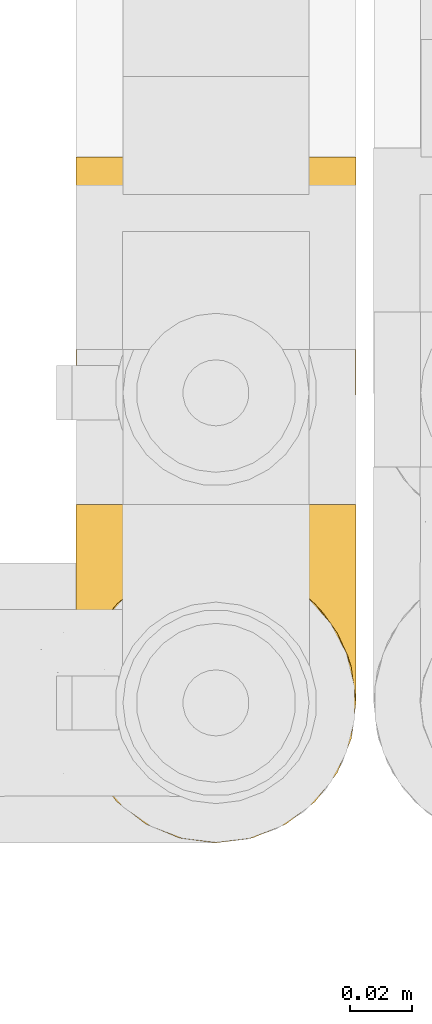
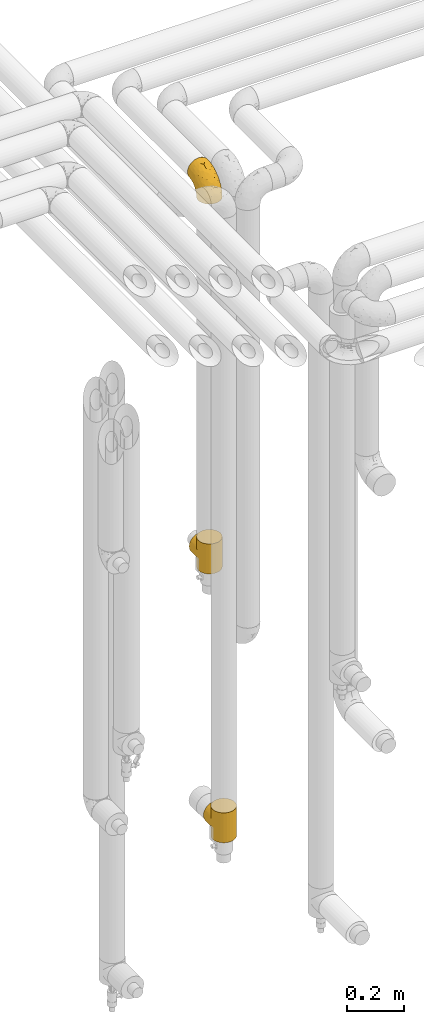
# One storey, part 258 of 827: 3 coverings.
"""IFC2X3 building model written with IfcOpenShell, lengths in millimetres."""

from ifc_helpers import new_model, entity, si_unit, converted_unit, derived_unit, direction, frame, origin, place, context, subcontext, project, spatial, faceted_brep, element, save


model = new_model("IFC2X3")

# Units and contexts
model_context = context("Model", 3, precision=0.01, world=origin(), true_north=direction((6.12303176911189e-17, 1.0)))
body_context = subcontext(model_context, "Body", "Model", "MODEL_VIEW")
ifc_project = project(units=[si_unit("LENGTHUNIT", "METRE", prefix="MILLI"), si_unit("AREAUNIT", "SQUARE_METRE"), si_unit("VOLUMEUNIT", "CUBIC_METRE"), converted_unit("PLANEANGLEUNIT", "DEGREE", entity("IfcRatioMeasure", 0.0174532925199433), si_unit("PLANEANGLEUNIT", "RADIAN"), dimensions=[0, 0, 0, 0, 0, 0, 0]), si_unit("MASSUNIT", "GRAM", prefix="KILO"), derived_unit("MASSDENSITYUNIT", [(si_unit("MASSUNIT", "GRAM", prefix="KILO"), 1), (si_unit("LENGTHUNIT", "METRE"), -3)]), derived_unit("MOMENTOFINERTIAUNIT", [(si_unit("LENGTHUNIT", "METRE"), 4)]), si_unit("TIMEUNIT", "SECOND"), si_unit("FREQUENCYUNIT", "HERTZ"), si_unit("THERMODYNAMICTEMPERATUREUNIT", "DEGREE_CELSIUS"), derived_unit("THERMALTRANSMITTANCEUNIT", [(si_unit("MASSUNIT", "GRAM", prefix="KILO"), 1), (si_unit("THERMODYNAMICTEMPERATUREUNIT", "KELVIN"), -1), (si_unit("TIMEUNIT", "SECOND"), -3)]), derived_unit("VOLUMETRICFLOWRATEUNIT", [(si_unit("LENGTHUNIT", "METRE"), 3), (si_unit("TIMEUNIT", "SECOND"), -1)]), derived_unit("MASSFLOWRATEUNIT", [(si_unit("MASSUNIT", "GRAM", prefix="KILO"), 1), (si_unit("TIMEUNIT", "SECOND"), -1)]), derived_unit("ROTATIONALFREQUENCYUNIT", [(si_unit("TIMEUNIT", "SECOND"), -1)]), si_unit("ELECTRICCURRENTUNIT", "AMPERE"), si_unit("ELECTRICVOLTAGEUNIT", "VOLT"), si_unit("POWERUNIT", "WATT"), si_unit("FORCEUNIT", "NEWTON", prefix="KILO"), si_unit("ILLUMINANCEUNIT", "LUX"), si_unit("LUMINOUSFLUXUNIT", "LUMEN"), si_unit("LUMINOUSINTENSITYUNIT", "CANDELA"), derived_unit("USERDEFINED", [(si_unit("MASSUNIT", "GRAM", prefix="KILO"), -1), (si_unit("LENGTHUNIT", "METRE"), -2), (si_unit("TIMEUNIT", "SECOND"), 3), (si_unit("LUMINOUSFLUXUNIT", "LUMEN"), 1)]), derived_unit("LINEARVELOCITYUNIT", [(si_unit("LENGTHUNIT", "METRE"), 1), (si_unit("TIMEUNIT", "SECOND"), -1)]), si_unit("PRESSUREUNIT", "PASCAL"), derived_unit("USERDEFINED", [(si_unit("LENGTHUNIT", "METRE"), -2), (si_unit("MASSUNIT", "GRAM", prefix="KILO"), 1), (si_unit("TIMEUNIT", "SECOND"), -2)]), derived_unit("LINEARFORCEUNIT", [(si_unit("MASSUNIT", "GRAM", prefix="KILO"), 1), (si_unit("LENGTHUNIT", "METRE"), 1), (si_unit("TIMEUNIT", "SECOND"), -2), (si_unit("LENGTHUNIT", "METRE"), -1)]), derived_unit("PLANARFORCEUNIT", [(si_unit("MASSUNIT", "GRAM", prefix="KILO"), 1), (si_unit("LENGTHUNIT", "METRE"), 1), (si_unit("TIMEUNIT", "SECOND"), -2), (si_unit("LENGTHUNIT", "METRE"), -2)])], contexts=[model_context])

# Site, building, storey
site_placement = place(None, origin())
site = spatial("IfcSite", under=ifc_project, at=site_placement, CompositionType="ELEMENT")
building_placement = place(site_placement, origin())
building = spatial("IfcBuilding", under=site, at=building_placement, CompositionType="ELEMENT")
storey_placement = place(building_placement, frame((0.0, 0.0, 28200.0)))
storey = spatial("IfcBuildingStorey", under=building, at=storey_placement, Name="08", CompositionType="ELEMENT", Elevation=28200.0)

# Coverings
covering_1_placement = place(storey_placement, frame((31537.51, 15764.46, 2922.4)))
element("IfcCovering", 1, at=covering_1_placement, inside=storey, Name=":ADSK_", ObjectType=":ADSK_", PredefinedType="INSULATION", context=body_context, shape_type="Brep", body=[
    faceted_brep([(90.76, 36.69, 1.6), (87.42, 27.15, 1.6), (82.04, 18.59, 1.6), (74.89, 11.44, 1.6), (66.33, 6.06, 1.6), (56.79, 2.73, 1.6), (46.75, 1.6, 1.6), (36.69, 2.73, 1.6), (27.15, 6.07, 1.6), (18.59, 11.45, 1.6), (11.44, 18.6, 1.6), (6.06, 27.16, 1.6), (2.73, 36.7, 1.6), (1.6, 46.75, 1.6), (2.73, 56.8, 1.6), (6.07, 66.34, 1.6), (11.45, 74.9, 1.6), (18.6, 82.05, 1.6), (27.16, 87.43, 1.6), (36.7, 90.76, 1.6), (46.75, 91.9, 1.6), (56.8, 90.76, 1.6), (66.34, 87.42, 1.6), (74.9, 82.04, 1.6), (82.05, 74.89, 1.6), (87.43, 66.33, 1.6), (90.76, 56.79, 1.6), (91.9, 46.75, 1.6), (35.06, 122.75, 33.98), (24.17, 122.75, 38.49), (14.82, 122.75, 45.67), (7.64, 122.75, 55.02), (3.13, 122.75, 65.91), (1.6, 122.75, 77.6), (3.13, 122.75, 89.28), (7.64, 122.75, 100.17), (14.82, 122.75, 109.52), (24.17, 122.75, 116.7), (35.06, 122.75, 121.21), (46.75, 122.75, 122.75), (58.43, 122.75, 121.21), (69.32, 122.75, 116.7), (78.67, 122.75, 109.52), (85.85, 122.75, 100.17), (90.36, 122.75, 89.28), (91.9, 122.75, 77.6), (90.36, 122.75, 65.91), (85.85, 122.75, 55.02), (78.67, 122.75, 45.67), (69.32, 122.75, 38.49), (58.43, 122.75, 33.98), (46.75, 122.75, 32.45), (46.75, 24.73, 72.81), (55.2, 29.08, 77.17), (46.75, 38.13, 86.21), (46.75, 85.31, 116.82), (54.53, 93.59, 118.49), (46.75, 100.54, 119.23), (59.63, 63.54, 105.14), (62.07, 38.98, 85.37), (71.86, 50.71, 89.33), (62.65, 93.33, 116.14), (71.33, 75.2, 105.06), (72.93, 100.46, 112.15), (91.2, 41.6, 22.95), (86.31, 80.86, 89.91), (80.89, 94.87, 103.39), (79.49, 67.96, 93.6), (90.68, 52.16, 51.41), (86.84, 52.1, 67.71), (87.38, 36.74, 43.53), (76.87, 17.11, 30.91), (83.73, 23.24, 23.58), (81.03, 29.18, 50.07), (91.9, 52.53, 30.68), (91.9, 60.77, 43.01), (91.9, 69.01, 55.34), (91.03, 100.68, 83.48), (87.58, 103.79, 94.96), (56.52, 16.37, 57.29), (46.75, 7.52, 39.03), (60.4, 7.31, 30.66), (91.9, 93.66, 71.81), (91.9, 102.83, 73.63), (91.9, 112.01, 75.46), (67.87, 18.17, 51.57), (90.35, 71.97, 73.13), (69.57, 9.83, 23.16), (46.75, 5.11, 23.8), (79.91, 45.97, 75.6), (91.9, 48.88, 12.33), (91.9, 50.71, 21.51), (74.99, 22.83, 50.46), (46.75, 51.54, 99.61), (91.9, 81.33, 63.57), (88.53, 31.74, 21.26), (72.65, 32.48, 69.54), (46.75, 68.42, 108.21), (62.97, 25.33, 68.42), (46.75, 16.13, 55.92), (66.2, 92.29, 19.36), (56.6, 94.12, 15.76), (59.89, 100.97, 26.13), (90.95, 95.91, 62.78), (90.22, 107.9, 63.65), (76.64, 87.24, 24.34), (71.58, 95.46, 28.46), (79.99, 90.41, 33.53), (89.54, 74.17, 39.46), (89.97, 83.77, 51.05), (81.32, 76.72, 10.94), (74.56, 84.44, 14.55), (84.15, 76.42, 22.21), (90.37, 90.07, 57.05), (87.82, 99.69, 54.0), (90.98, 61.74, 29.19), (90.96, 58.16, 18.85), (85.14, 112.6, 52.84), (58.11, 110.45, 31.47), (46.75, 107.32, 28.31), (78.39, 108.48, 43.0), (88.22, 66.63, 16.9), (66.06, 115.23, 35.98), (68.6, 105.79, 33.91), (63.78, 89.6, 9.97), (88.42, 69.39, 25.93), (90.61, 66.99, 35.61), (83.8, 102.31, 47.45), (77.98, 99.54, 38.26), (91.22, 55.27, 11.7), (83.46, 82.03, 30.13), (46.75, 94.71, 12.12), (46.75, 96.03, 17.02), (84.66, 94.11, 44.39), (86.33, 84.21, 39.83), (46.75, 101.67, 22.67), (46.75, 112.22, 29.63), (15.1, 108.48, 43.0), (9.69, 102.31, 47.45), (15.52, 99.54, 38.26), (8.83, 94.11, 44.38), (35.39, 110.46, 31.47), (12.18, 76.74, 10.93), (1.6, 50.71, 21.51), (2.53, 58.17, 18.84), (2.27, 55.27, 11.7), (36.9, 94.12, 15.76), (27.31, 92.3, 19.36), (33.62, 100.98, 26.14), (5.07, 69.41, 25.94), (9.36, 76.44, 22.21), (5.27, 66.65, 16.9), (27.43, 115.24, 35.98), (1.6, 102.83, 73.63), (1.6, 112.01, 75.46), (10.05, 82.05, 30.12), (16.87, 87.25, 24.33), (8.35, 112.6, 52.84), (3.27, 107.9, 63.65), (1.6, 93.66, 71.81), (21.94, 95.48, 28.45), (29.72, 89.6, 9.97), (1.6, 60.77, 43.01), (1.6, 69.01, 55.34), (3.96, 74.17, 39.46), (1.6, 48.88, 12.33), (18.95, 84.45, 14.54), (2.54, 95.91, 62.78), (3.12, 90.07, 57.05), (1.6, 81.33, 63.57), (2.51, 61.75, 29.2), (3.52, 83.77, 51.05), (7.17, 84.21, 39.81), (1.6, 52.53, 30.68), (13.52, 90.42, 33.52), (2.88, 67.0, 35.61), (5.67, 99.69, 54.0), (24.89, 105.8, 33.91), (12.6, 94.87, 103.39), (7.18, 80.86, 89.91), (14.0, 67.95, 93.6), (22.16, 75.17, 105.05), (21.61, 50.65, 89.27), (3.14, 71.97, 73.13), (6.65, 52.08, 67.67), (20.82, 32.46, 69.49), (31.41, 38.98, 85.36), (5.91, 103.79, 94.96), (2.46, 100.68, 83.48), (33.87, 63.54, 105.14), (30.84, 93.32, 116.13), (38.96, 93.59, 118.49), (20.56, 100.44, 112.15), (2.81, 52.17, 51.41), (6.1, 36.75, 43.51), (2.29, 41.61, 22.95), (33.08, 7.31, 30.66), (16.61, 17.12, 30.91), (36.96, 16.37, 57.3), (9.75, 23.26, 23.58), (25.61, 18.17, 51.56), (30.5, 25.33, 68.41), (23.91, 9.84, 23.16), (12.45, 29.19, 50.07), (18.49, 22.84, 50.45), (4.96, 31.75, 21.25), (13.56, 45.96, 75.56), (38.28, 29.07, 77.16)], [[[0, 1, 2, 3, 4, 5, 6, 7, 8, 9, 10, 11, 12, 13, 14, 15, 16, 17, 18, 19, 20, 21, 22, 23, 24, 25, 26, 27]], [[28, 29, 30, 31, 32, 33, 34, 35, 36, 37, 38, 39, 40, 41, 42, 43, 44, 45, 46, 47, 48, 49, 50, 51]], [[52, 53, 54]], [[55, 56, 57]], [[58, 59, 60]], [[61, 62, 63]], [[27, 64, 0]], [[65, 66, 67]], [[41, 40, 61]], [[68, 69, 70]], [[66, 43, 42]], [[63, 42, 41]], [[71, 72, 73]], [[72, 2, 1]], [[68, 74, 75, 76]], [[45, 44, 77]], [[43, 78, 44]], [[79, 80, 81]], [[77, 82, 83, 84, 45]], [[79, 81, 85]], [[71, 2, 72]], [[65, 86, 77]], [[4, 81, 5]], [[66, 65, 78]], [[4, 3, 87]], [[81, 88, 5]], [[63, 66, 42]], [[68, 70, 64]], [[67, 60, 89]], [[71, 3, 2]], [[64, 27, 90, 91, 74]], [[92, 71, 73]], [[40, 57, 56]], [[59, 93, 54]], [[86, 76, 94, 82]], [[1, 0, 95]], [[58, 62, 61]], [[60, 96, 89]], [[85, 81, 87]], [[56, 97, 58]], [[65, 67, 69]], [[87, 81, 4]], [[67, 89, 69]], [[61, 63, 41]], [[95, 72, 1]], [[73, 72, 70]], [[69, 73, 70]], [[73, 89, 96]], [[3, 71, 87]], [[85, 87, 71]], [[58, 61, 56]], [[59, 58, 93]], [[76, 86, 68]], [[69, 89, 73]], [[68, 86, 69]], [[65, 69, 86]], [[68, 64, 74]], [[95, 64, 70]], [[98, 79, 85]], [[79, 52, 99, 80]], [[66, 62, 67]], [[62, 58, 60]], [[62, 60, 67]], [[59, 98, 96]], [[59, 96, 60]], [[96, 85, 92]], [[88, 81, 80]], [[88, 6, 5]], [[66, 63, 62]], [[64, 95, 0]], [[72, 95, 70]], [[77, 44, 78]], [[86, 82, 77]], [[40, 39, 57]], [[96, 98, 85]], [[40, 56, 61]], [[66, 78, 43]], [[77, 78, 65]], [[79, 98, 53]], [[96, 92, 73]], [[85, 71, 92]], [[97, 56, 55]], [[97, 93, 58]], [[53, 98, 59]], [[54, 53, 59]], [[79, 53, 52]], [[100, 101, 102]], [[46, 45, 84, 83]], [[103, 104, 82]], [[82, 104, 83]], [[105, 106, 107]], [[108, 109, 76]], [[110, 111, 112]], [[103, 113, 114]], [[115, 74, 116]], [[48, 47, 117]], [[118, 102, 119]], [[49, 48, 120]], [[74, 91, 116]], [[116, 121, 115]], [[49, 122, 50]], [[123, 106, 102]], [[124, 111, 22]], [[125, 126, 115]], [[23, 22, 111]], [[24, 110, 121]], [[120, 127, 128]], [[90, 26, 129]], [[27, 26, 90]], [[121, 125, 115]], [[24, 121, 25]], [[130, 105, 107]], [[129, 25, 116]], [[21, 20, 131]], [[120, 123, 122]], [[112, 105, 130]], [[50, 118, 51]], [[21, 124, 22]], [[101, 131, 132]], [[117, 120, 48]], [[24, 23, 110]], [[127, 114, 133]], [[75, 108, 76]], [[107, 134, 130]], [[133, 114, 113]], [[129, 116, 91]], [[25, 121, 116]], [[121, 112, 125]], [[75, 74, 115]], [[101, 135, 102]], [[131, 101, 21]], [[101, 100, 124]], [[128, 127, 133]], [[119, 136, 51, 118]], [[104, 47, 46]], [[83, 104, 46]], [[117, 104, 114]], [[101, 124, 21]], [[111, 124, 100]], [[102, 118, 123]], [[133, 134, 107]], [[111, 110, 23]], [[114, 104, 103]], [[94, 76, 109]], [[121, 110, 112]], [[122, 118, 50]], [[134, 109, 108]], [[133, 107, 128]], [[112, 108, 125]], [[126, 125, 108]], [[108, 75, 126]], [[75, 115, 126]], [[109, 134, 133]], [[130, 108, 112]], [[108, 130, 134]], [[105, 112, 111]], [[111, 100, 105]], [[106, 105, 100]], [[102, 106, 100]], [[128, 106, 123]], [[90, 129, 91]], [[25, 129, 26]], [[104, 117, 47]], [[117, 114, 127]], [[82, 94, 103]], [[113, 94, 109]], [[94, 113, 103]], [[133, 113, 109]], [[106, 128, 107]], [[123, 120, 128]], [[120, 122, 49]], [[118, 122, 123]], [[135, 101, 132]], [[135, 119, 102]], [[117, 127, 120]], [[30, 29, 137]], [[138, 139, 140]], [[51, 136, 119, 141]], [[142, 17, 16]], [[143, 144, 145]], [[146, 147, 148]], [[149, 150, 151]], [[152, 29, 28]], [[33, 32, 153, 154]], [[150, 155, 156]], [[157, 31, 30]], [[153, 158, 159]], [[29, 152, 137]], [[148, 141, 119]], [[156, 160, 147]], [[148, 135, 146]], [[137, 138, 157]], [[19, 161, 146]], [[162, 163, 164]], [[14, 13, 165]], [[153, 32, 158]], [[147, 161, 166]], [[18, 17, 166]], [[167, 168, 169]], [[166, 150, 156]], [[151, 150, 142]], [[151, 170, 149]], [[151, 16, 15]], [[171, 140, 172]], [[165, 143, 145]], [[173, 170, 144]], [[142, 166, 17]], [[19, 131, 20]], [[144, 170, 151]], [[18, 161, 19]], [[173, 144, 143]], [[140, 139, 174]], [[171, 164, 163]], [[164, 172, 155]], [[151, 15, 144]], [[145, 15, 14]], [[173, 162, 170]], [[149, 175, 164]], [[19, 146, 131]], [[132, 131, 146]], [[160, 148, 147]], [[159, 158, 167]], [[135, 132, 146]], [[158, 32, 31]], [[157, 158, 31]], [[167, 158, 176]], [[166, 161, 18]], [[146, 161, 147]], [[148, 177, 141]], [[171, 168, 140]], [[171, 163, 169]], [[151, 142, 16]], [[166, 142, 150]], [[152, 141, 177]], [[51, 141, 28]], [[138, 140, 176]], [[172, 140, 174]], [[175, 149, 170]], [[164, 150, 149]], [[170, 162, 175]], [[162, 164, 175]], [[155, 172, 174]], [[171, 172, 164]], [[155, 174, 156]], [[164, 155, 150]], [[160, 156, 174]], [[147, 166, 156]], [[139, 160, 174]], [[148, 160, 177]], [[15, 145, 144]], [[165, 145, 14]], [[137, 157, 30]], [[158, 157, 176]], [[168, 167, 176]], [[169, 159, 167]], [[140, 168, 176]], [[169, 168, 171]], [[137, 177, 139]], [[160, 139, 177]], [[141, 152, 28]], [[137, 152, 177]], [[148, 119, 135]], [[157, 138, 176]], [[139, 138, 137]], [[178, 179, 180]], [[181, 180, 182]], [[179, 183, 184]], [[185, 186, 182]], [[187, 188, 179]], [[188, 33, 154, 153, 159]], [[181, 189, 190]], [[35, 34, 187]], [[191, 38, 190]], [[192, 178, 181]], [[179, 184, 180]], [[192, 190, 37]], [[37, 190, 38]], [[36, 35, 178]], [[54, 93, 186]], [[35, 187, 178]], [[193, 194, 184]], [[195, 173, 143, 165, 13]], [[195, 193, 173]], [[193, 163, 162, 173]], [[13, 12, 195]], [[8, 7, 196]], [[9, 197, 10]], [[198, 80, 99, 52]], [[196, 7, 88]], [[197, 199, 10]], [[182, 189, 181]], [[200, 198, 201]], [[200, 196, 198]], [[9, 8, 202]], [[194, 199, 203]], [[192, 37, 36]], [[80, 196, 88]], [[183, 159, 169, 163]], [[188, 34, 33]], [[202, 200, 197]], [[185, 203, 204]], [[202, 8, 196]], [[10, 199, 11]], [[12, 11, 205]], [[38, 191, 57]], [[189, 97, 191]], [[203, 199, 197]], [[205, 199, 194]], [[204, 203, 197]], [[184, 203, 206]], [[200, 202, 196]], [[197, 9, 202]], [[207, 54, 186]], [[97, 55, 191]], [[194, 203, 184]], [[183, 163, 193]], [[184, 206, 180]], [[183, 193, 184]], [[205, 195, 12]], [[193, 195, 194]], [[80, 198, 196]], [[207, 186, 201]], [[182, 180, 206]], [[181, 178, 180]], [[185, 182, 206]], [[182, 186, 189]], [[203, 185, 206]], [[185, 200, 201]], [[7, 6, 88]], [[178, 192, 36]], [[190, 192, 181]], [[199, 205, 11]], [[195, 205, 194]], [[159, 183, 188]], [[179, 188, 183]], [[57, 191, 55]], [[57, 39, 38]], [[189, 191, 190]], [[188, 187, 34]], [[178, 187, 179]], [[186, 93, 189]], [[197, 200, 204]], [[185, 204, 200]], [[189, 93, 97]], [[207, 198, 52]], [[185, 201, 186]], [[198, 207, 201]], [[54, 207, 52]]]),
])
covering_2_placement = place(storey_placement, frame((31537.51, 15664.46, 251.5)))
element("IfcCovering", 2, at=covering_2_placement, inside=storey, Name=":ADSK_", ObjectType=":ADSK_", PredefinedType="INSULATION", context=body_context, shape_type="Brep", body=[
    faceted_brep([(57.34, 90.63, 107.89), (46.75, 91.9, 128.0), (58.43, 90.36, 128.0), (66.9, 87.15, 104.4), (69.32, 85.85, 128.0), (74.89, 82.05, 99.3), (78.67, 78.67, 128.0), (46.75, 91.9, 109.15), (46.75, 91.9, 18.85), (57.34, 90.63, 20.11), (46.75, 91.9, 0.0), (81.23, 75.89, 93.14), (85.99, 69.06, 86.32), (85.85, 69.32, 128.0), (89.3, 61.82, 79.08), (90.36, 58.43, 128.0), (91.25, 54.34, 71.59), (91.9, 46.75, 128.0), (91.9, 46.75, 64.0), (91.25, 54.34, 56.41), (91.9, 46.75, 0.0), (2.1, 53.5, 70.75), (1.6, 46.75, 128.0), (3.13, 58.43, 128.0), (7.64, 69.32, 128.0), (6.23, 66.68, 83.94), (9.95, 72.92, 90.17), (14.82, 78.67, 128.0), (1.6, 46.75, 64.0), (2.1, 53.5, 57.25), (1.6, 46.75, 0.0), (3.64, 60.17, 77.43), (21.07, 83.88, 101.14), (24.17, 85.85, 128.0), (28.59, 88.08, 105.34), (29.61, 88.1, 128.0), (35.06, 90.36, 128.0), (37.3, 90.9, 108.15), (14.87, 78.72, 95.98), (37.3, 90.9, 19.85), (69.32, 7.64, 0.0), (58.43, 3.13, 0.0), (46.75, 1.6, 0.0), (35.06, 3.13, 0.0), (24.17, 7.64, 0.0), (14.82, 14.82, 0.0), (7.64, 24.17, 0.0), (3.13, 35.06, 0.0), (3.13, 58.43, 0.0), (7.64, 69.32, 0.0), (14.82, 78.67, 0.0), (24.17, 85.85, 0.0), (29.61, 88.1, 0.0), (35.06, 90.36, 0.0), (58.43, 90.36, 0.0), (69.32, 85.85, 0.0), (78.67, 78.67, 0.0), (85.85, 69.32, 0.0), (90.36, 58.43, 0.0), (90.36, 35.06, 0.0), (85.85, 24.17, 0.0), (78.67, 14.82, 0.0), (14.82, 14.82, 128.0), (24.17, 7.64, 128.0), (35.06, 3.13, 128.0), (46.75, 1.6, 128.0), (58.43, 3.13, 128.0), (69.32, 7.64, 128.0), (78.67, 14.82, 128.0), (85.85, 24.17, 128.0), (90.36, 35.06, 128.0), (3.13, 35.06, 128.0), (7.64, 24.17, 128.0), (3.64, 60.17, 50.57), (6.23, 66.68, 44.06), (9.95, 72.92, 37.83), (14.87, 78.72, 32.02), (21.07, 83.88, 26.86), (28.59, 88.08, 22.66), (66.9, 87.15, 23.6), (74.89, 82.05, 28.7), (81.23, 75.89, 34.86), (85.99, 69.06, 41.68), (89.3, 61.82, 48.92), (14.82, 110.75, 95.93), (24.17, 110.75, 103.1), (29.61, 110.75, 105.36), (35.06, 110.75, 107.61), (46.75, 110.75, 109.15), (58.43, 110.75, 107.61), (69.32, 110.75, 103.1), (78.67, 110.75, 95.93), (85.85, 110.75, 86.57), (90.36, 110.75, 75.69), (91.9, 110.75, 64.0), (90.36, 110.75, 52.31), (85.85, 110.75, 41.42), (78.67, 110.75, 32.07), (69.32, 110.75, 24.9), (58.43, 110.75, 20.39), (46.75, 110.75, 18.85), (35.06, 110.75, 20.39), (29.61, 110.75, 22.64), (24.17, 110.75, 24.9), (14.82, 110.75, 32.07), (7.64, 110.75, 41.42), (3.13, 110.75, 52.31), (1.6, 110.75, 64.0), (3.13, 110.75, 75.69), (7.64, 110.75, 86.57)], [[[0, 1, 2]], [[3, 2, 4]], [[5, 4, 6]], [[0, 7, 1]], [[8, 9, 10]], [[5, 3, 4]], [[0, 2, 3]], [[6, 11, 5]], [[12, 11, 13]], [[13, 11, 6]], [[14, 13, 15]], [[16, 15, 17]], [[14, 12, 13]], [[18, 16, 17]], [[19, 18, 20]], [[14, 15, 16]], [[21, 22, 23]], [[23, 24, 25]], [[26, 24, 27]], [[26, 25, 24]], [[21, 28, 22]], [[28, 29, 30]], [[25, 31, 23]], [[21, 23, 31]], [[32, 27, 33]], [[34, 33, 35, 36]], [[37, 36, 1]], [[32, 38, 27]], [[37, 34, 36]], [[7, 37, 1]], [[10, 39, 8]], [[32, 33, 34]], [[27, 38, 26]], [[40, 41, 42, 43, 44, 45, 46, 47, 30, 48, 49, 50, 51, 52, 53, 10, 54, 55, 56, 57, 58, 20, 59, 60, 61]], [[62, 63, 64, 65, 66, 67, 68, 69, 70, 17, 15, 13, 6, 4, 2, 1, 36, 35, 33, 27, 24, 23, 22, 71, 72]], [[63, 62, 45, 44]], [[42, 65, 64, 43]], [[44, 43, 64, 63]], [[46, 72, 71, 47]], [[22, 28, 30, 47, 71]], [[45, 62, 72, 46]], [[73, 74, 48]], [[29, 73, 48]], [[30, 29, 48]], [[49, 75, 50]], [[49, 48, 74]], [[75, 49, 74]], [[76, 77, 50]], [[78, 39, 53]], [[78, 53, 52, 51]], [[77, 78, 51]], [[50, 77, 51]], [[39, 10, 53]], [[76, 50, 75]], [[79, 80, 55]], [[9, 79, 54]], [[10, 9, 54]], [[54, 79, 55]], [[80, 56, 55]], [[80, 81, 56]], [[82, 83, 57]], [[83, 19, 58]], [[81, 57, 56]], [[81, 82, 57]], [[57, 83, 58]], [[19, 20, 58]], [[18, 17, 70, 59, 20]], [[59, 70, 69, 60]], [[69, 68, 61, 60]], [[61, 68, 67, 40]], [[40, 67, 66, 41]], [[41, 66, 65, 42]], [[84, 85, 86, 87, 88, 89, 90, 91, 92, 93, 94, 95, 96, 97, 98, 99, 100, 101, 102, 103, 104, 105, 106, 107, 108, 109]], [[37, 7, 88]], [[37, 88, 87]], [[34, 87, 86, 85]], [[34, 37, 87]], [[84, 38, 32]], [[34, 85, 32]], [[32, 85, 84]], [[26, 84, 109]], [[25, 109, 108]], [[21, 108, 107]], [[25, 26, 109]], [[21, 31, 108]], [[28, 21, 107]], [[25, 108, 31]], [[84, 26, 38]], [[29, 107, 106]], [[106, 105, 74]], [[75, 105, 104]], [[75, 74, 105]], [[29, 28, 107]], [[74, 73, 106]], [[29, 106, 73]], [[77, 104, 103]], [[78, 103, 102, 101]], [[39, 101, 100]], [[77, 76, 104]], [[39, 78, 101]], [[8, 39, 100]], [[77, 103, 78]], [[104, 76, 75]], [[9, 100, 99]], [[79, 99, 98]], [[80, 98, 97]], [[9, 8, 100]], [[80, 79, 98]], [[9, 99, 79]], [[97, 81, 80]], [[82, 81, 96]], [[96, 81, 97]], [[83, 96, 95]], [[19, 95, 94]], [[83, 82, 96]], [[18, 19, 94]], [[83, 95, 19]], [[16, 94, 93]], [[93, 92, 14]], [[11, 92, 91]], [[11, 12, 92]], [[16, 18, 94]], [[12, 14, 92]], [[16, 93, 14]], [[5, 91, 90]], [[3, 90, 89]], [[0, 89, 88]], [[3, 5, 90]], [[7, 0, 88]], [[3, 89, 0]], [[91, 5, 11]]]),
])
covering_3_placement = place(storey_placement, frame((31537.51, 15764.46, 1341.5)))
element("IfcCovering", 3, at=covering_3_placement, inside=storey, Name=":ADSK_", ObjectType=":ADSK_", PredefinedType="INSULATION", context=body_context, shape_type="Brep", body=[
    faceted_brep([(2.1, 53.5, 70.75), (1.6, 46.75, 128.0), (3.13, 58.43, 128.0), (7.64, 69.32, 128.0), (6.23, 66.68, 83.94), (9.95, 72.92, 90.17), (14.82, 78.67, 128.0), (1.6, 46.75, 64.0), (2.1, 53.5, 57.25), (1.6, 46.75, 0.0), (3.64, 60.17, 77.43), (21.07, 83.88, 101.14), (24.17, 85.85, 128.0), (28.59, 88.08, 105.34), (29.61, 88.1, 128.0), (35.06, 90.36, 128.0), (37.3, 90.9, 108.15), (46.75, 91.9, 128.0), (14.87, 78.72, 95.98), (46.75, 91.9, 109.15), (46.75, 91.9, 0.0), (37.3, 90.9, 19.85), (46.75, 91.9, 18.85), (57.34, 90.63, 107.89), (58.43, 90.36, 128.0), (66.9, 87.15, 104.4), (69.32, 85.85, 128.0), (74.89, 82.05, 99.3), (78.67, 78.67, 128.0), (57.34, 90.63, 20.11), (81.23, 75.89, 93.14), (85.99, 69.06, 86.32), (85.85, 69.32, 128.0), (89.3, 61.82, 79.08), (90.36, 58.43, 128.0), (91.25, 54.34, 71.59), (91.9, 46.75, 128.0), (91.9, 46.75, 64.0), (91.25, 54.34, 56.41), (91.9, 46.75, 0.0), (69.32, 7.64, 0.0), (58.43, 3.13, 0.0), (46.75, 1.6, 0.0), (35.06, 3.13, 0.0), (24.17, 7.64, 0.0), (14.82, 14.82, 0.0), (7.64, 24.17, 0.0), (3.13, 35.06, 0.0), (3.13, 58.43, 0.0), (7.64, 69.32, 0.0), (14.82, 78.67, 0.0), (24.17, 85.85, 0.0), (29.61, 88.1, 0.0), (35.06, 90.36, 0.0), (58.43, 90.36, 0.0), (69.32, 85.85, 0.0), (78.67, 78.67, 0.0), (85.85, 69.32, 0.0), (90.36, 58.43, 0.0), (90.36, 35.06, 0.0), (85.85, 24.17, 0.0), (78.67, 14.82, 0.0), (14.82, 14.82, 128.0), (24.17, 7.64, 128.0), (35.06, 3.13, 128.0), (46.75, 1.6, 128.0), (58.43, 3.13, 128.0), (69.32, 7.64, 128.0), (78.67, 14.82, 128.0), (85.85, 24.17, 128.0), (90.36, 35.06, 128.0), (3.13, 35.06, 128.0), (7.64, 24.17, 128.0), (3.64, 60.17, 50.57), (6.23, 66.68, 44.06), (9.95, 72.92, 37.83), (14.87, 78.72, 32.02), (21.07, 83.88, 26.86), (28.59, 88.08, 22.66), (66.9, 87.15, 23.6), (74.89, 82.05, 28.7), (81.23, 75.89, 34.86), (85.99, 69.06, 41.68), (89.3, 61.82, 48.92), (14.82, 110.75, 95.93), (24.17, 110.75, 103.1), (29.61, 110.75, 105.36), (35.06, 110.75, 107.61), (46.75, 110.75, 109.15), (58.43, 110.75, 107.61), (69.32, 110.75, 103.1), (78.67, 110.75, 95.93), (85.85, 110.75, 86.57), (90.36, 110.75, 75.69), (91.9, 110.75, 64.0), (90.36, 110.75, 52.31), (85.85, 110.75, 41.42), (78.67, 110.75, 32.07), (69.32, 110.75, 24.9), (58.43, 110.75, 20.39), (46.75, 110.75, 18.85), (35.06, 110.75, 20.39), (29.61, 110.75, 22.64), (24.17, 110.75, 24.9), (14.82, 110.75, 32.07), (7.64, 110.75, 41.42), (3.13, 110.75, 52.31), (1.6, 110.75, 64.0), (3.13, 110.75, 75.69), (7.64, 110.75, 86.57)], [[[0, 1, 2]], [[2, 3, 4]], [[5, 3, 6]], [[5, 4, 3]], [[0, 7, 1]], [[7, 8, 9]], [[4, 10, 2]], [[0, 2, 10]], [[11, 6, 12]], [[13, 12, 14, 15]], [[16, 15, 17]], [[11, 18, 6]], [[16, 13, 15]], [[19, 16, 17]], [[20, 21, 22]], [[11, 12, 13]], [[6, 18, 5]], [[23, 17, 24]], [[25, 24, 26]], [[27, 26, 28]], [[23, 19, 17]], [[22, 29, 20]], [[27, 25, 26]], [[23, 24, 25]], [[28, 30, 27]], [[31, 30, 32]], [[32, 30, 28]], [[33, 32, 34]], [[35, 34, 36]], [[33, 31, 32]], [[37, 35, 36]], [[38, 37, 39]], [[33, 34, 35]], [[40, 41, 42, 43, 44, 45, 46, 47, 9, 48, 49, 50, 51, 52, 53, 20, 54, 55, 56, 57, 58, 39, 59, 60, 61]], [[62, 63, 64, 65, 66, 67, 68, 69, 70, 36, 34, 32, 28, 26, 24, 17, 15, 14, 12, 6, 3, 2, 1, 71, 72]], [[63, 62, 45, 44]], [[42, 65, 64, 43]], [[44, 43, 64, 63]], [[46, 72, 71, 47]], [[1, 7, 9, 47, 71]], [[45, 62, 72, 46]], [[73, 74, 48]], [[8, 73, 48]], [[9, 8, 48]], [[49, 75, 50]], [[49, 48, 74]], [[75, 49, 74]], [[76, 77, 50]], [[78, 21, 53]], [[78, 53, 52, 51]], [[77, 78, 51]], [[50, 77, 51]], [[21, 20, 53]], [[76, 50, 75]], [[79, 80, 55]], [[29, 79, 54]], [[20, 29, 54]], [[54, 79, 55]], [[80, 56, 55]], [[80, 81, 56]], [[82, 83, 57]], [[83, 38, 58]], [[81, 57, 56]], [[81, 82, 57]], [[57, 83, 58]], [[38, 39, 58]], [[37, 36, 70, 59, 39]], [[59, 70, 69, 60]], [[69, 68, 61, 60]], [[61, 68, 67, 40]], [[40, 67, 66, 41]], [[41, 66, 65, 42]], [[84, 85, 86, 87, 88, 89, 90, 91, 92, 93, 94, 95, 96, 97, 98, 99, 100, 101, 102, 103, 104, 105, 106, 107, 108, 109]], [[16, 19, 88]], [[16, 88, 87]], [[13, 87, 86, 85]], [[13, 16, 87]], [[84, 18, 11]], [[13, 85, 11]], [[11, 85, 84]], [[5, 84, 109]], [[4, 109, 108]], [[0, 108, 107]], [[4, 5, 109]], [[0, 10, 108]], [[7, 0, 107]], [[4, 108, 10]], [[84, 5, 18]], [[8, 107, 106]], [[106, 105, 74]], [[75, 105, 104]], [[75, 74, 105]], [[8, 7, 107]], [[74, 73, 106]], [[8, 106, 73]], [[77, 104, 103]], [[78, 103, 102, 101]], [[21, 101, 100]], [[77, 76, 104]], [[21, 78, 101]], [[22, 21, 100]], [[77, 103, 78]], [[104, 76, 75]], [[29, 100, 99]], [[79, 99, 98]], [[80, 98, 97]], [[29, 22, 100]], [[80, 79, 98]], [[29, 99, 79]], [[97, 81, 80]], [[82, 81, 96]], [[96, 81, 97]], [[83, 96, 95]], [[38, 95, 94]], [[83, 82, 96]], [[37, 38, 94]], [[83, 95, 38]], [[35, 94, 93]], [[93, 92, 33]], [[30, 92, 91]], [[30, 31, 92]], [[35, 37, 94]], [[31, 33, 92]], [[35, 93, 33]], [[27, 91, 90]], [[25, 90, 89]], [[23, 89, 88]], [[25, 27, 90]], [[19, 23, 88]], [[25, 89, 23]], [[91, 27, 30]]]),
])

save(model, "model.ifc")
